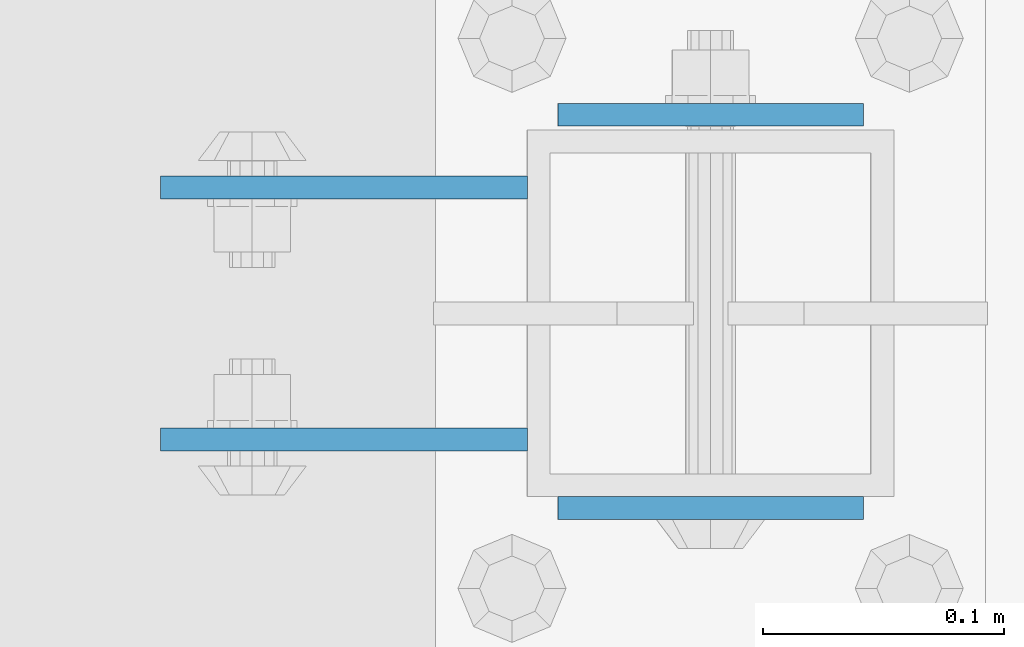
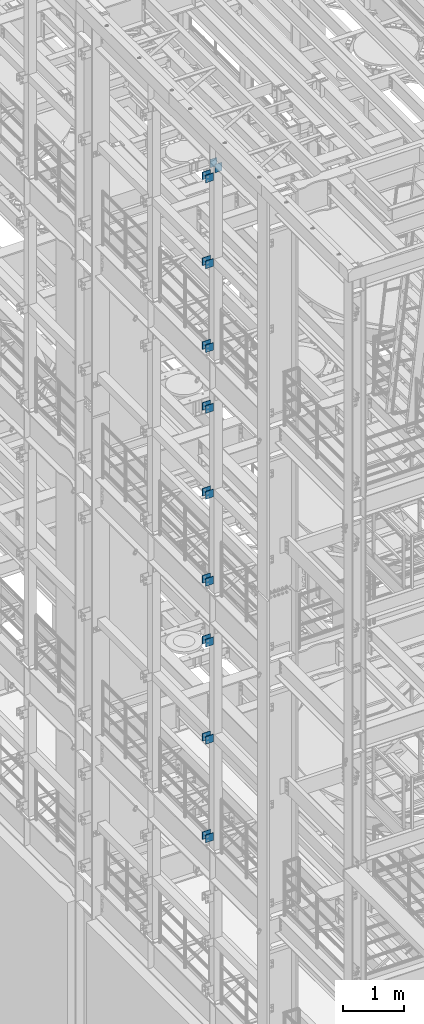
# One storey, part 1181 of 1876: 20 beams, 4 elements without a shape of their own.
"""IFC2X3 building model written with IfcOpenShell, lengths in millimetres."""

from ifc_helpers import new_model, si_unit, frame, origin_with_axes, place, context, subcontext, project, spatial, faceted_brep, material, type_object, element, aggregate, save


model = new_model("IFC2X3")

# Units and contexts
model_context = context("Model", 3, precision=1e-05, world=origin_with_axes())
body_context = subcontext(model_context, "Body", "Model", "MODEL_VIEW")
ifc_project = project(units=[si_unit("LENGTHUNIT", "METRE", prefix="MILLI"), si_unit("AREAUNIT", "SQUARE_METRE"), si_unit("VOLUMEUNIT", "CUBIC_METRE"), si_unit("MASSUNIT", "GRAM", prefix="KILO"), si_unit("TIMEUNIT", "SECOND"), si_unit("PLANEANGLEUNIT", "RADIAN"), si_unit("SOLIDANGLEUNIT", "STERADIAN"), si_unit("THERMODYNAMICTEMPERATUREUNIT", "DEGREE_CELSIUS"), si_unit("LUMINOUSINTENSITYUNIT", "LUMEN")], contexts=[model_context])

# Site, building, storey
site_placement = place(None, origin_with_axes())
site = spatial("IfcSite", under=ifc_project, at=site_placement, CompositionType="ELEMENT")
building_placement = place(site_placement, origin_with_axes())
building = spatial("IfcBuilding", under=site, at=building_placement, Name="Undefined", CompositionType="ELEMENT")
storey_placement = place(building_placement, origin_with_axes())
storey = spatial("IfcBuildingStorey", under=building, at=storey_placement, Name="Undefined", CompositionType="ELEMENT", Elevation=0.0)

# Assembly, beams
assembly_1_placement = place(storey_placement, origin_with_axes())
assembly_1 = element("IfcElementAssembly", 1, at=assembly_1_placement, inside=storey, Name="BEAM", AssemblyPlace="NOTDEFINED", PredefinedType="RIGID_FRAME")
ifc_material = material(Name="STEEL/A36")
beam_type_1 = type_object("IfcBeamType", PredefinedType="NOTDEFINED")
beam_1_placement = place(assembly_1_placement, frame((-76.2000002548894, -2487.6125, 18275.3), z_axis=(0.0, 0.0, -1.0), x_axis=(-1.0, 0.0, 0.0)))
beam_1 = element("IfcBeam", 2, at=beam_1_placement, type_object=beam_type_1, material=ifc_material, Name="PLATE", context=body_context, shape_type="Brep", body=[
    faceted_brep([(0.0, 4.76249999999982, -76.1999999999998), (3.63797880709171e-12, 4.76249999999982, 76.1999969482422), (152.399993896484, 4.76250000000073, 76.1999969482422), (152.4, 4.76249999999982, -76.1999999999998), (3.63797880709171e-12, -4.76249999999982, 76.1999969482422), (152.399993896484, -4.76250000000073, 76.1999969482422), (0.0, -4.76249999999982, -76.1999999999998), (152.4, -4.76249999999982, -76.1999999999998)], [[[0, 1, 2, 3]], [[4, 5, 2, 1]], [[4, 6, 7, 5]], [[6, 0, 3, 7]], [[5, 7, 3, 2]], [[6, 4, 1, 0]]]),
])
beam_2_placement = place(assembly_1_placement, frame((-76.2000002548894, -2592.3875, 18275.3), z_axis=(0.0, 0.0, -1.0), x_axis=(-1.0, 0.0, 0.0)))
beam_2 = element("IfcBeam", 3, at=beam_2_placement, type_object=beam_type_1, material=ifc_material, Name="PLATE", context=body_context, shape_type="Brep", body=[
    faceted_brep([(0.0, 4.76249999999982, -76.1999999999998), (3.63797880709171e-12, 4.76249999999982, 76.1999969482422), (152.399993896484, 4.76250000000073, 76.1999969482422), (152.4, 4.76249999999982, -76.1999999999998), (3.63797880709171e-12, -4.76249999999982, 76.1999969482422), (152.399993896484, -4.76250000000073, 76.1999969482422), (0.0, -4.76249999999982, -76.1999999999998), (152.4, -4.76249999999982, -76.1999999999998)], [[[0, 1, 2, 3]], [[4, 5, 2, 1]], [[4, 6, 7, 5]], [[6, 0, 3, 7]], [[5, 7, 3, 2]], [[6, 4, 1, 0]]]),
])
beam_3_placement = place(assembly_1_placement, frame((-76.2000002548895, -2487.6125, 21678.9), z_axis=(0.0, 0.0, -1.0), x_axis=(-1.0, 0.0, 0.0)))
beam_3 = element("IfcBeam", 4, at=beam_3_placement, type_object=beam_type_1, material=ifc_material, Name="PLATE", context=body_context, shape_type="Brep", body=[
    faceted_brep([(0.0, 4.76249999999982, -76.1999999999998), (3.63797880709171e-12, 4.76249999999982, 76.1999969482422), (152.399993896484, 4.76250000000073, 76.1999969482422), (152.4, 4.76249999999982, -76.1999999999998), (3.63797880709171e-12, -4.76249999999982, 76.1999969482422), (152.399993896484, -4.76250000000073, 76.1999969482422), (0.0, -4.76249999999982, -76.1999999999998), (152.4, -4.76249999999982, -76.1999999999998)], [[[0, 1, 2, 3]], [[4, 5, 2, 1]], [[4, 6, 7, 5]], [[6, 0, 3, 7]], [[5, 7, 3, 2]], [[6, 4, 1, 0]]]),
])
beam_4_placement = place(assembly_1_placement, frame((-76.2000002548895, -2592.3875, 21678.9), z_axis=(0.0, 0.0, -1.0), x_axis=(-1.0, 0.0, 0.0)))
beam_4 = element("IfcBeam", 5, at=beam_4_placement, type_object=beam_type_1, material=ifc_material, Name="PLATE", context=body_context, shape_type="Brep", body=[
    faceted_brep([(0.0, 4.76249999999982, -76.1999999999998), (3.63797880709171e-12, 4.76249999999982, 76.1999969482422), (152.399993896484, 4.76250000000073, 76.1999969482422), (152.4, 4.76249999999982, -76.1999999999998), (3.63797880709171e-12, -4.76249999999982, 76.1999969482422), (152.399993896484, -4.76250000000073, 76.1999969482422), (0.0, -4.76249999999982, -76.1999999999998), (152.4, -4.76249999999982, -76.1999999999998)], [[[0, 1, 2, 3]], [[4, 5, 2, 1]], [[4, 6, 7, 5]], [[6, 0, 3, 7]], [[5, 7, 3, 2]], [[6, 4, 1, 0]]]),
])
beam_5_placement = place(assembly_1_placement, frame((-76.2000002548895, -2487.6125, 19958.05), z_axis=(0.0, 0.0, -1.0), x_axis=(-1.0, 0.0, 0.0)))
beam_5 = element("IfcBeam", 6, at=beam_5_placement, type_object=beam_type_1, material=ifc_material, Name="PLATE", context=body_context, shape_type="Brep", body=[
    faceted_brep([(0.0, 4.76249999999982, -76.1999999999998), (3.63797880709171e-12, 4.76249999999982, 76.1999969482422), (152.399993896484, 4.76250000000073, 76.1999969482422), (152.4, 4.76249999999982, -76.1999999999998), (3.63797880709171e-12, -4.76249999999982, 76.1999969482422), (152.399993896484, -4.76250000000073, 76.1999969482422), (0.0, -4.76249999999982, -76.1999999999998), (152.4, -4.76249999999982, -76.1999999999998)], [[[0, 1, 2, 3]], [[4, 5, 2, 1]], [[4, 6, 7, 5]], [[6, 0, 3, 7]], [[5, 7, 3, 2]], [[6, 4, 1, 0]]]),
])
beam_6_placement = place(assembly_1_placement, frame((-76.2000002548895, -2592.3875, 19958.05), z_axis=(0.0, 0.0, -1.0), x_axis=(-1.0, 0.0, 0.0)))
beam_6 = element("IfcBeam", 7, at=beam_6_placement, type_object=beam_type_1, material=ifc_material, Name="PLATE", context=body_context, shape_type="Brep", body=[
    faceted_brep([(0.0, 4.76249999999982, -76.1999999999998), (3.63797880709171e-12, 4.76249999999982, 76.1999969482422), (152.399993896484, 4.76250000000073, 76.1999969482422), (152.4, 4.76249999999982, -76.1999999999998), (3.63797880709171e-12, -4.76249999999982, 76.1999969482422), (152.399993896484, -4.76250000000073, 76.1999969482422), (0.0, -4.76249999999982, -76.1999999999998), (152.4, -4.76249999999982, -76.1999999999998)], [[[0, 1, 2, 3]], [[4, 5, 2, 1]], [[4, 6, 7, 5]], [[6, 0, 3, 7]], [[5, 7, 3, 2]], [[6, 4, 1, 0]]]),
])
aggregate(assembly_1, [beam_1, beam_2, beam_3, beam_4, beam_5, beam_6])

assembly_2_placement = place(storey_placement, origin_with_axes())
assembly_2 = element("IfcElementAssembly", 8, at=assembly_2_placement, inside=storey, Name="BEAM", AssemblyPlace="NOTDEFINED", PredefinedType="RIGID_FRAME")
beam_7_placement = place(assembly_2_placement, frame((-76.1999999999999, -2487.6125, 13589.0), z_axis=(0.0, 0.0, -1.0), x_axis=(-1.0, 0.0, 0.0)))
beam_7 = element("IfcBeam", 9, at=beam_7_placement, type_object=beam_type_1, material=ifc_material, Name="PLATE", context=body_context, shape_type="Brep", body=[
    faceted_brep([(0.0, 4.76249999999982, -76.1999999999998), (3.63797880709171e-12, 4.76249999999982, 76.1999969482422), (152.399993896484, 4.76250000000073, 76.1999969482422), (152.4, 4.76249999999982, -76.1999999999998), (3.63797880709171e-12, -4.76249999999982, 76.1999969482422), (152.399993896484, -4.76250000000073, 76.1999969482422), (0.0, -4.76249999999982, -76.1999999999998), (152.4, -4.76249999999982, -76.1999999999998)], [[[0, 1, 2, 3]], [[4, 5, 2, 1]], [[4, 6, 7, 5]], [[6, 0, 3, 7]], [[5, 7, 3, 2]], [[6, 4, 1, 0]]]),
])
beam_8_placement = place(assembly_2_placement, frame((-76.1999999999999, -2592.3875, 13589.0), z_axis=(0.0, 0.0, -1.0), x_axis=(-1.0, 0.0, 0.0)))
beam_8 = element("IfcBeam", 10, at=beam_8_placement, type_object=beam_type_1, material=ifc_material, Name="PLATE", context=body_context, shape_type="Brep", body=[
    faceted_brep([(0.0, 4.76249999999982, -76.1999999999998), (3.63797880709171e-12, 4.76249999999982, 76.1999969482422), (152.399993896484, 4.76250000000073, 76.1999969482422), (152.4, 4.76249999999982, -76.1999999999998), (3.63797880709171e-12, -4.76249999999982, 76.1999969482422), (152.399993896484, -4.76250000000073, 76.1999969482422), (0.0, -4.76249999999982, -76.1999999999998), (152.4, -4.76249999999982, -76.1999999999998)], [[[0, 1, 2, 3]], [[4, 5, 2, 1]], [[4, 6, 7, 5]], [[6, 0, 3, 7]], [[5, 7, 3, 2]], [[6, 4, 1, 0]]]),
])
beam_9_placement = place(assembly_2_placement, frame((-76.2, -2487.6125, 17056.1), z_axis=(0.0, 0.0, -1.0), x_axis=(-1.0, 0.0, 0.0)))
beam_9 = element("IfcBeam", 11, at=beam_9_placement, type_object=beam_type_1, material=ifc_material, Name="PLATE", context=body_context, shape_type="Brep", body=[
    faceted_brep([(0.0, 4.76249999999982, -76.1999999999998), (3.63797880709171e-12, 4.76249999999982, 76.1999969482422), (152.399993896484, 4.76250000000073, 76.1999969482422), (152.4, 4.76249999999982, -76.1999999999998), (3.63797880709171e-12, -4.76249999999982, 76.1999969482422), (152.399993896484, -4.76250000000073, 76.1999969482422), (0.0, -4.76249999999982, -76.1999999999998), (152.4, -4.76249999999982, -76.1999999999998)], [[[0, 1, 2, 3]], [[4, 5, 2, 1]], [[4, 6, 7, 5]], [[6, 0, 3, 7]], [[5, 7, 3, 2]], [[6, 4, 1, 0]]]),
])
beam_10_placement = place(assembly_2_placement, frame((-76.2, -2592.3875, 17056.1), z_axis=(0.0, 0.0, -1.0), x_axis=(-1.0, 0.0, 0.0)))
beam_10 = element("IfcBeam", 12, at=beam_10_placement, type_object=beam_type_1, material=ifc_material, Name="PLATE", context=body_context, shape_type="Brep", body=[
    faceted_brep([(0.0, 4.76249999999982, -76.1999999999998), (3.63797880709171e-12, 4.76249999999982, 76.1999969482422), (152.399993896484, 4.76250000000073, 76.1999969482422), (152.4, 4.76249999999982, -76.1999999999998), (3.63797880709171e-12, -4.76249999999982, 76.1999969482422), (152.399993896484, -4.76250000000073, 76.1999969482422), (0.0, -4.76249999999982, -76.1999999999998), (152.4, -4.76249999999982, -76.1999999999998)], [[[0, 1, 2, 3]], [[4, 5, 2, 1]], [[4, 6, 7, 5]], [[6, 0, 3, 7]], [[5, 7, 3, 2]], [[6, 4, 1, 0]]]),
])
beam_11_placement = place(assembly_2_placement, frame((-76.2, -2487.6125, 15335.25), z_axis=(0.0, 0.0, -1.0), x_axis=(-1.0, 0.0, 0.0)))
beam_11 = element("IfcBeam", 13, at=beam_11_placement, type_object=beam_type_1, material=ifc_material, Name="PLATE", context=body_context, shape_type="Brep", body=[
    faceted_brep([(0.0, 4.76249999999982, -76.1999999999998), (3.63797880709171e-12, 4.76249999999982, 76.1999969482422), (152.399993896484, 4.76250000000073, 76.1999969482422), (152.4, 4.76249999999982, -76.1999999999998), (3.63797880709171e-12, -4.76249999999982, 76.1999969482422), (152.399993896484, -4.76250000000073, 76.1999969482422), (0.0, -4.76249999999982, -76.1999999999998), (152.4, -4.76249999999982, -76.1999999999998)], [[[0, 1, 2, 3]], [[4, 5, 2, 1]], [[4, 6, 7, 5]], [[6, 0, 3, 7]], [[5, 7, 3, 2]], [[6, 4, 1, 0]]]),
])
beam_12_placement = place(assembly_2_placement, frame((-76.2, -2592.3875, 15335.25), z_axis=(0.0, 0.0, -1.0), x_axis=(-1.0, 0.0, 0.0)))
beam_12 = element("IfcBeam", 14, at=beam_12_placement, type_object=beam_type_1, material=ifc_material, Name="PLATE", context=body_context, shape_type="Brep", body=[
    faceted_brep([(0.0, 4.76249999999982, -76.1999999999998), (3.63797880709171e-12, 4.76249999999982, 76.1999969482422), (152.399993896484, 4.76250000000073, 76.1999969482422), (152.4, 4.76249999999982, -76.1999999999998), (3.63797880709171e-12, -4.76249999999982, 76.1999969482422), (152.399993896484, -4.76250000000073, 76.1999969482422), (0.0, -4.76249999999982, -76.1999999999998), (152.4, -4.76249999999982, -76.1999999999998)], [[[0, 1, 2, 3]], [[4, 5, 2, 1]], [[4, 6, 7, 5]], [[6, 0, 3, 7]], [[5, 7, 3, 2]], [[6, 4, 1, 0]]]),
])
aggregate(assembly_2, [beam_7, beam_8, beam_9, beam_10, beam_11, beam_12])

assembly_3_placement = place(storey_placement, origin_with_axes())
assembly_3 = element("IfcElementAssembly", 15, at=assembly_3_placement, inside=storey, Name="BEAM", AssemblyPlace="NOTDEFINED", PredefinedType="RIGID_FRAME")
beam_13_placement = place(assembly_3_placement, frame((-76.1999999999999, -2487.6125, 12369.8), z_axis=(0.0, 0.0, -1.0), x_axis=(-1.0, 0.0, 0.0)))
beam_13 = element("IfcBeam", 16, at=beam_13_placement, type_object=beam_type_1, material=ifc_material, Name="PLATE", context=body_context, shape_type="Brep", body=[
    faceted_brep([(0.0, 4.76249999999982, -76.1999999999998), (3.63797880709171e-12, 4.76249999999982, 76.1999969482422), (152.399993896484, 4.76250000000073, 76.1999969482422), (152.4, 4.76249999999982, -76.1999999999998), (3.63797880709171e-12, -4.76249999999982, 76.1999969482422), (152.399993896484, -4.76250000000073, 76.1999969482422), (0.0, -4.76249999999982, -76.1999999999998), (152.4, -4.76249999999982, -76.1999999999998)], [[[0, 1, 2, 3]], [[4, 5, 2, 1]], [[4, 6, 7, 5]], [[6, 0, 3, 7]], [[5, 7, 3, 2]], [[6, 4, 1, 0]]]),
])
beam_14_placement = place(assembly_3_placement, frame((-76.1999999999999, -2592.3875, 12369.8), z_axis=(0.0, 0.0, -1.0), x_axis=(-1.0, 0.0, 0.0)))
beam_14 = element("IfcBeam", 17, at=beam_14_placement, type_object=beam_type_1, material=ifc_material, Name="PLATE", context=body_context, shape_type="Brep", body=[
    faceted_brep([(0.0, 4.76249999999982, -76.1999999999998), (3.63797880709171e-12, 4.76249999999982, 76.1999969482422), (152.399993896484, 4.76250000000073, 76.1999969482422), (152.4, 4.76249999999982, -76.1999999999998), (3.63797880709171e-12, -4.76249999999982, 76.1999969482422), (152.399993896484, -4.76250000000073, 76.1999969482422), (0.0, -4.76249999999982, -76.1999999999998), (152.4, -4.76249999999982, -76.1999999999998)], [[[0, 1, 2, 3]], [[4, 5, 2, 1]], [[4, 6, 7, 5]], [[6, 0, 3, 7]], [[5, 7, 3, 2]], [[6, 4, 1, 0]]]),
])
beam_15_placement = place(assembly_3_placement, frame((-76.2, -2487.6125, 8445.5), z_axis=(0.0, 0.0, -1.0), x_axis=(-1.0, 0.0, 0.0)))
beam_15 = element("IfcBeam", 18, at=beam_15_placement, type_object=beam_type_1, material=ifc_material, Name="PLATE", context=body_context, shape_type="Brep", body=[
    faceted_brep([(0.0, 4.76249999999982, -76.1999999999998), (3.63797880709171e-12, 4.76249999999982, 76.1999969482422), (152.399993896484, 4.76250000000073, 76.1999969482422), (152.4, 4.76249999999982, -76.1999999999998), (3.63797880709171e-12, -4.76249999999982, 76.1999969482422), (152.399993896484, -4.76250000000073, 76.1999969482422), (0.0, -4.76249999999982, -76.1999999999998), (152.4, -4.76249999999982, -76.1999999999998)], [[[0, 1, 2, 3]], [[4, 5, 2, 1]], [[4, 6, 7, 5]], [[6, 0, 3, 7]], [[5, 7, 3, 2]], [[6, 4, 1, 0]]]),
])
beam_16_placement = place(assembly_3_placement, frame((-76.2, -2592.3875, 8445.5), z_axis=(0.0, 0.0, -1.0), x_axis=(-1.0, 0.0, 0.0)))
beam_16 = element("IfcBeam", 19, at=beam_16_placement, type_object=beam_type_1, material=ifc_material, Name="PLATE", context=body_context, shape_type="Brep", body=[
    faceted_brep([(0.0, 4.76249999999982, -76.1999999999998), (3.63797880709171e-12, 4.76249999999982, 76.1999969482422), (152.399993896484, 4.76250000000073, 76.1999969482422), (152.4, 4.76249999999982, -76.1999999999998), (3.63797880709171e-12, -4.76249999999982, 76.1999969482422), (152.399993896484, -4.76250000000073, 76.1999969482422), (0.0, -4.76249999999982, -76.1999999999998), (152.4, -4.76249999999982, -76.1999999999998)], [[[0, 1, 2, 3]], [[4, 5, 2, 1]], [[4, 6, 7, 5]], [[6, 0, 3, 7]], [[5, 7, 3, 2]], [[6, 4, 1, 0]]]),
])
beam_17_placement = place(assembly_3_placement, frame((-76.2, -2487.6125, 10420.35), z_axis=(0.0, 0.0, -1.0), x_axis=(-1.0, 0.0, 0.0)))
beam_17 = element("IfcBeam", 20, at=beam_17_placement, type_object=beam_type_1, material=ifc_material, Name="PLATE", context=body_context, shape_type="Brep", body=[
    faceted_brep([(0.0, 4.76249999999982, -76.1999999999998), (3.63797880709171e-12, 4.76249999999982, 76.1999969482422), (152.399993896484, 4.76250000000073, 76.1999969482422), (152.4, 4.76249999999982, -76.1999999999998), (3.63797880709171e-12, -4.76249999999982, 76.1999969482422), (152.399993896484, -4.76250000000073, 76.1999969482422), (0.0, -4.76249999999982, -76.1999999999998), (152.4, -4.76249999999982, -76.1999999999998)], [[[0, 1, 2, 3]], [[4, 5, 2, 1]], [[4, 6, 7, 5]], [[6, 0, 3, 7]], [[5, 7, 3, 2]], [[6, 4, 1, 0]]]),
])
beam_18_placement = place(assembly_3_placement, frame((-76.2, -2592.3875, 10420.35), z_axis=(0.0, 0.0, -1.0), x_axis=(-1.0, 0.0, 0.0)))
beam_18 = element("IfcBeam", 21, at=beam_18_placement, type_object=beam_type_1, material=ifc_material, Name="PLATE", context=body_context, shape_type="Brep", body=[
    faceted_brep([(0.0, 4.76249999999982, -76.1999999999998), (3.63797880709171e-12, 4.76249999999982, 76.1999969482422), (152.399993896484, 4.76250000000073, 76.1999969482422), (152.4, 4.76249999999982, -76.1999999999998), (3.63797880709171e-12, -4.76249999999982, 76.1999969482422), (152.399993896484, -4.76250000000073, 76.1999969482422), (0.0, -4.76249999999982, -76.1999999999998), (152.4, -4.76249999999982, -76.1999999999998)], [[[0, 1, 2, 3]], [[4, 5, 2, 1]], [[4, 6, 7, 5]], [[6, 0, 3, 7]], [[5, 7, 3, 2]], [[6, 4, 1, 0]]]),
])
aggregate(assembly_3, [beam_13, beam_14, beam_15, beam_16, beam_17, beam_18])

assembly_4_placement = place(storey_placement, origin_with_axes())
assembly_4 = element("IfcElementAssembly", 22, at=assembly_4_placement, inside=storey, Name="BEAM", AssemblyPlace="NOTDEFINED", PredefinedType="RIGID_FRAME")
beam_type_2 = type_object("IfcBeamType", PredefinedType="NOTDEFINED")
beam_19_placement = place(assembly_4_placement, frame((-63.5, -2457.45, 21850.35), z_axis=(0.0, 0.0, -1.0), x_axis=(1.0, 0.0, 0.0)))
beam_19 = element("IfcBeam", 23, at=beam_19_placement, type_object=beam_type_2, material=ifc_material, Name="PLATE", context=body_context, shape_type="Brep", body=[
    faceted_brep([(0.0, 4.76249999999982, -82.5499999999993), (0.0, 4.76249999999982, 82.5499999999993), (127.0, 4.76249999999982, 82.5499999999993), (127.0, 4.76249999999982, -82.5499999999993), (0.0, -4.76249999999982, 82.5499999999993), (127.0, -4.76249999999982, 82.5499999999993), (0.0, -4.76249999999982, -82.5499999999993), (127.0, -4.76249999999982, -82.5499999999993)], [[[0, 1, 2, 3]], [[1, 4, 5, 2]], [[4, 6, 7, 5]], [[6, 0, 3, 7]], [[5, 7, 3, 2]], [[6, 4, 1, 0]]]),
])
beam_20_placement = place(assembly_4_placement, frame((-63.5, -2620.9625, 21850.35), z_axis=(0.0, 0.0, -1.0), x_axis=(1.0, 0.0, 0.0)))
beam_20 = element("IfcBeam", 24, at=beam_20_placement, type_object=beam_type_2, material=ifc_material, Name="PLATE", context=body_context, shape_type="Brep", body=[
    faceted_brep([(0.0, 4.76249999999982, -82.5499999999993), (0.0, 4.76249999999982, 82.5499999999993), (127.0, 4.76249999999982, 82.5499999999993), (127.0, 4.76249999999982, -82.5499999999993), (0.0, -4.76249999999982, 82.5499999999993), (127.0, -4.76249999999982, 82.5499999999993), (0.0, -4.76249999999982, -82.5499999999993), (127.0, -4.76249999999982, -82.5499999999993)], [[[0, 1, 2, 3]], [[1, 4, 5, 2]], [[4, 6, 7, 5]], [[6, 0, 3, 7]], [[5, 7, 3, 2]], [[6, 4, 1, 0]]]),
])
aggregate(assembly_4, [beam_19, beam_20])

save(model, "model.ifc")
